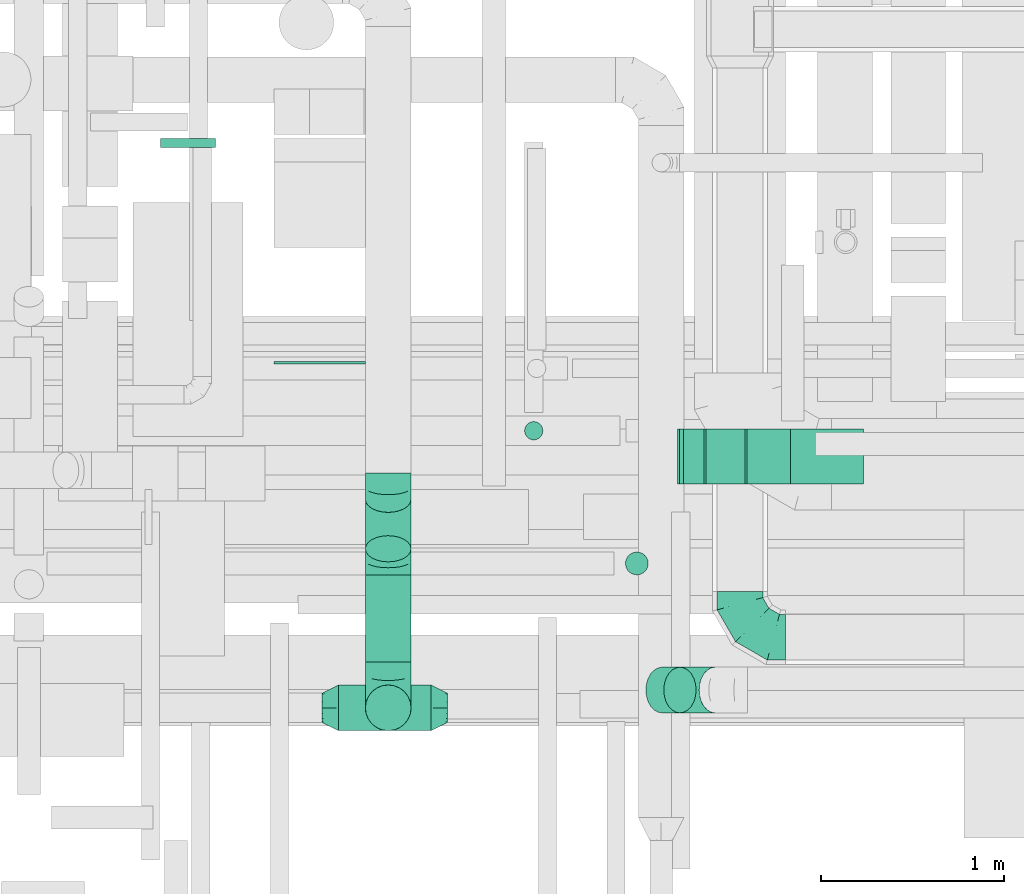
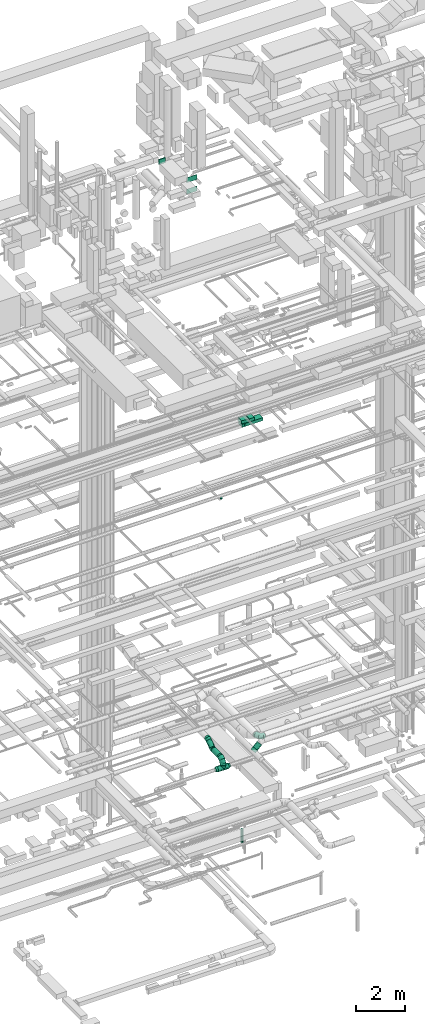
# One storey, part 142 of 337: 14 flow segments, 8 flow fittings.
"""IFC2X3 building model written with IfcOpenShell, lengths in millimetres."""

from ifc_helpers import new_model, entity, si_unit, converted_unit, derived_unit, direction, frame, frame_2d, origin, origin_2d_with_axis, place, context, subcontext, project, spatial, rectangle, circle, extrude, faceted_brep, source, transform, mapped, material, type_object, type_shapes, element, save


model = new_model("IFC2X3")

# Units and contexts
model_context = context("Model", 3, precision=0.01, world=origin(), true_north=direction((6.12303176911189e-17, 1.0)))
body_context = subcontext(model_context, "Body", "Model", "MODEL_VIEW")
ifc_project = project(units=[si_unit("LENGTHUNIT", "METRE", prefix="MILLI"), si_unit("AREAUNIT", "SQUARE_METRE"), si_unit("VOLUMEUNIT", "CUBIC_METRE"), converted_unit("PLANEANGLEUNIT", "DEGREE", entity("IfcRatioMeasure", 0.0174532925199433), si_unit("PLANEANGLEUNIT", "RADIAN"), dimensions=[0, 0, 0, 0, 0, 0, 0]), si_unit("MASSUNIT", "GRAM", prefix="KILO"), derived_unit("MASSDENSITYUNIT", [(si_unit("MASSUNIT", "GRAM", prefix="KILO"), 1), (si_unit("LENGTHUNIT", "METRE"), -3)]), derived_unit("MOMENTOFINERTIAUNIT", [(si_unit("LENGTHUNIT", "METRE"), 4)]), si_unit("TIMEUNIT", "SECOND"), si_unit("FREQUENCYUNIT", "HERTZ"), si_unit("THERMODYNAMICTEMPERATUREUNIT", "DEGREE_CELSIUS"), derived_unit("THERMALTRANSMITTANCEUNIT", [(si_unit("MASSUNIT", "GRAM", prefix="KILO"), 1), (si_unit("THERMODYNAMICTEMPERATUREUNIT", "KELVIN"), -1), (si_unit("TIMEUNIT", "SECOND"), -3)]), derived_unit("VOLUMETRICFLOWRATEUNIT", [(si_unit("LENGTHUNIT", "METRE"), 3), (si_unit("TIMEUNIT", "SECOND"), -1)]), derived_unit("MASSFLOWRATEUNIT", [(si_unit("MASSUNIT", "GRAM", prefix="KILO"), 1), (si_unit("TIMEUNIT", "SECOND"), -1)]), derived_unit("ROTATIONALFREQUENCYUNIT", [(si_unit("TIMEUNIT", "SECOND"), -1)]), si_unit("ELECTRICCURRENTUNIT", "AMPERE"), si_unit("ELECTRICVOLTAGEUNIT", "VOLT"), si_unit("POWERUNIT", "WATT"), si_unit("FORCEUNIT", "NEWTON", prefix="KILO"), si_unit("ILLUMINANCEUNIT", "LUX"), si_unit("LUMINOUSFLUXUNIT", "LUMEN"), si_unit("LUMINOUSINTENSITYUNIT", "CANDELA"), derived_unit("USERDEFINED", [(si_unit("MASSUNIT", "GRAM", prefix="KILO"), -1), (si_unit("LENGTHUNIT", "METRE"), -2), (si_unit("TIMEUNIT", "SECOND"), 3), (si_unit("LUMINOUSFLUXUNIT", "LUMEN"), 1)]), derived_unit("LINEARVELOCITYUNIT", [(si_unit("LENGTHUNIT", "METRE"), 1), (si_unit("TIMEUNIT", "SECOND"), -1)]), si_unit("PRESSUREUNIT", "PASCAL"), derived_unit("USERDEFINED", [(si_unit("LENGTHUNIT", "METRE"), -2), (si_unit("MASSUNIT", "GRAM", prefix="KILO"), 1), (si_unit("TIMEUNIT", "SECOND"), -2)]), derived_unit("LINEARFORCEUNIT", [(si_unit("MASSUNIT", "GRAM", prefix="KILO"), 1), (si_unit("LENGTHUNIT", "METRE"), 1), (si_unit("TIMEUNIT", "SECOND"), -2), (si_unit("LENGTHUNIT", "METRE"), -1)]), derived_unit("PLANARFORCEUNIT", [(si_unit("MASSUNIT", "GRAM", prefix="KILO"), 1), (si_unit("LENGTHUNIT", "METRE"), 1), (si_unit("TIMEUNIT", "SECOND"), -2), (si_unit("LENGTHUNIT", "METRE"), -2)])], contexts=[model_context])

# Site, building, storey
site_placement = place(None, origin())
site = spatial("IfcSite", under=ifc_project, at=site_placement, CompositionType="ELEMENT")
building_placement = place(site_placement, origin())
building = spatial("IfcBuilding", under=site, at=building_placement, CompositionType="ELEMENT")
storey_placement = place(building_placement, origin())
storey = spatial("IfcBuildingStorey", under=building, at=storey_placement, CompositionType="ELEMENT", Elevation=0.0)

# Flow segments
duct_segment_type_1 = type_object("IfcDuctSegmentType", PredefinedType="NOTDEFINED")
flow_segment_1_placement = place(storey_placement, frame((36571.74, 9425.61, 18590.0)))
element("IfcFlowSegment", 1, at=flow_segment_1_placement, inside=storey, type_object=duct_segment_type_1, context=body_context, shape_type="SweptSolid", body=[
    extrude(rectangle(XDim=848.292132121106, YDim=300.0, at=origin_2d_with_axis()), frame((424.15, 150.0, 0.0)), (0.0, 0.0, 1.0), 150.000000000001),
])
flow_segment_2_placement = place(storey_placement, frame((36784.11, 9425.09, 18750.0)))
element("IfcFlowSegment", 2, at=flow_segment_2_placement, inside=storey, type_object=duct_segment_type_1, context=body_context, shape_type="SweptSolid", body=[
    extrude(rectangle(XDim=235.998435102064, YDim=300.0, at=origin_2d_with_axis()), frame((118.0, 150.0, 0.0), z_axis=(0.0, 0.0, 1.0), x_axis=(-1.0, 0.0, 0.0)), (0.0, 0.0, 1.0), 150.000000000001),
])
flow_segment_3_placement = place(storey_placement, frame((36403.1, 9425.09, 18750.96)))
element("IfcFlowSegment", 3, at=flow_segment_3_placement, inside=storey, type_object=duct_segment_type_1, context=body_context, shape_type="SweptSolid", body=[
    extrude(rectangle(XDim=149.999999999999, YDim=299.999999999999, at=frame_2d((0.0, 0.0), x_axis=(0.0, 1.0))), frame((5.98, 150.0, 103.33), z_axis=(0.996815278738972, 0.0, -0.0797452197472972), x_axis=(0.0, 1.0, 0.0)), (0.0, 0.0, 1.0), 358.22680686157),
])
flow_segment_4_placement = place(storey_placement, frame((36436.92, 9425.61, 18580.9)))
element("IfcFlowSegment", 4, at=flow_segment_4_placement, inside=storey, type_object=duct_segment_type_1, context=body_context, shape_type="SweptSolid", body=[
    extrude(rectangle(XDim=150.000000000002, YDim=111.97128059236, at=frame_2d((0.0, 0.0), x_axis=(0.0, 1.0))), frame((61.61, 0.0, 79.1), z_axis=(0.0, 1.0, 0.0), x_axis=(-0.997008847092297, 0.0, -0.0772875075266911)), (0.0, 0.0, 1.0), 299.999999999999),
])
duct_segment_type_2 = type_object("IfcDuctSegmentType", PredefinedType="NOTDEFINED")
flow_segment_5_placement = place(storey_placement, frame((36116.53, 8925.87, -1728.0)))
element("IfcFlowSegment", 5, at=flow_segment_5_placement, inside=storey, type_object=duct_segment_type_2, context=body_context, shape_type="SweptSolid", body=[
    extrude(circle(Radius=62.5, at=origin_2d_with_axis()), frame((64.1, 64.1, 0.0), z_axis=(0.0, 0.0, 1.0), x_axis=(0.0, 1.0, 0.0)), (0.0, 0.0, 1.0), 653.000000000004),
])
flow_segment_6_placement = place(storey_placement, frame((34548.9, 8073.43, 2823.4)))
element("IfcFlowSegment", 6, at=flow_segment_6_placement, inside=storey, type_object=duct_segment_type_2, context=body_context, shape_type="SweptSolid", body=[
    extrude(circle(Radius=125.0, at=origin_2d_with_axis()), frame((0.0, 126.6, 126.6), z_axis=(1.0, 0.0, 0.0), x_axis=(0.0, -1.0, 0.0)), (0.0, 0.0, 1.0), 504.999999999993),
])
flow_segment_7_placement = place(storey_placement, frame((35564.72, 9664.09, 15150.0)))
element("IfcFlowSegment", 7, at=flow_segment_7_placement, inside=storey, type_object=duct_segment_type_2, context=body_context, shape_type="SweptSolid", body=[
    extrude(circle(Radius=50.0, at=origin_2d_with_axis()), frame((51.6, 51.6, 0.0)), (0.0, 0.0, 1.0), 49.9999996080384),
])
flow_segment_8_placement = place(storey_placement, frame((36326.28, 8170.92, 3192.71)))
element("IfcFlowSegment", 8, at=flow_segment_8_placement, inside=storey, type_object=duct_segment_type_2, context=body_context, shape_type="SweptSolid", body=[
    extrude(circle(Radius=125.0, at=origin_2d_with_axis()), frame((90.06, 126.6, 89.91), z_axis=(0.706492479137975, 0.0, 0.707720550020613), x_axis=(0.0, 1.0, 0.0)), (0.0, 0.0, 1.0), 274.124638638619),
])
flow_segment_9_placement = place(storey_placement, frame((34693.82, 8996.95, 3311.22)))
element("IfcFlowSegment", 9, at=flow_segment_9_placement, inside=storey, type_object=duct_segment_type_2, context=body_context, shape_type="SweptSolid", body=[
    extrude(circle(Radius=125.0, at=origin_2d_with_axis()), frame((126.6, 73.29, 103.99), z_axis=(0.0, 0.819152044288994, 0.573576436351043), x_axis=(1.0, 0.0, 0.0)), (0.0, 0.0, 1.0), 330.515708334412),
])
flow_segment_10_placement = place(storey_placement, frame((34693.82, 8450.02, 3243.4)))
element("IfcFlowSegment", 10, at=flow_segment_10_placement, inside=storey, type_object=duct_segment_type_2, context=body_context, shape_type="SweptSolid", body=[
    extrude(circle(Radius=125.0, at=origin_2d_with_axis()), frame((126.6, 0.0, 126.6), z_axis=(0.0, 1.0, 0.0), x_axis=(-1.0, 0.0, 0.0)), (0.0, 0.0, 1.0), 476.823539571613),
])
flow_segment_11_placement = place(storey_placement, frame((34693.82, 8073.43, 3095.0)))
element("IfcFlowSegment", 11, at=flow_segment_11_placement, inside=storey, type_object=duct_segment_type_2, context=body_context, shape_type="SweptSolid", body=[
    extrude(circle(Radius=125.0, at=origin_2d_with_axis()), frame((126.6, 126.6, 0.0), z_axis=(0.0, 0.0, 1.0), x_axis=(-1.0, 0.0, 0.0)), (0.0, 0.0, 1.0), 24.9999999998828),
])
duct_segment_type_3 = type_object("IfcDuctSegmentType", PredefinedType="NOTDEFINED")
flow_segment_12_placement = place(storey_placement, frame((33575.03, 11265.73, 31575.0)))
element("IfcFlowSegment", 12, at=flow_segment_12_placement, inside=storey, type_object=duct_segment_type_3, context=body_context, shape_type="SweptSolid", body=[
    extrude(rectangle(XDim=49.2338702333314, YDim=300.000000000001, at=origin_2d_with_axis()), frame((150.0, 24.62, 0.0), z_axis=(0.0, 0.0, 1.0), x_axis=(0.0, 1.0, 0.0)), (0.0, 0.0, 1.0), 250.000000000004),
])
flow_segment_13_placement = place(storey_placement, frame((34195.98, 10082.41, 30600.0)))
element("IfcFlowSegment", 13, at=flow_segment_13_placement, inside=storey, type_object=duct_segment_type_3, context=body_context, shape_type="SweptSolid", body=[
    extrude(rectangle(XDim=12.2733718566518, YDim=499.999999999999, at=origin_2d_with_axis()), frame((250.0, 6.14, 0.0), z_axis=(0.0, 0.0, 1.0), x_axis=(0.0, -1.0, 0.0)), (0.0, 0.0, 1.0), 250.000000000004),
])
flow_segment_14_placement = place(storey_placement, frame((34195.98, 10082.41, 31175.0)))
element("IfcFlowSegment", 14, at=flow_segment_14_placement, inside=storey, type_object=duct_segment_type_3, context=body_context, shape_type="SweptSolid", body=[
    extrude(rectangle(XDim=11.954017716561, YDim=499.999999999999, at=origin_2d_with_axis()), frame((250.0, 5.98, 0.0), z_axis=(0.0, 0.0, 1.0), x_axis=(0.0, -1.0, 0.0)), (0.0, 0.0, 1.0), 250.000000000004),
])

# Flow fittings
ifc_material = material()
duct_fitting_type_1 = type_object("IfcDuctFittingType", PredefinedType="NOTDEFINED", material=ifc_material)
shared_shape_1 = source(origin(), body_context, "Body", "Brep", [
    faceted_brep([(-250.0, 0.0, -125.0), (-250.0, -32.35, -120.74), (-250.0, -62.5, -108.25), (-250.0, -88.39, -88.39), (-250.0, -108.25, -62.5), (-250.0, -120.74, -32.35), (-250.0, -125.0, 0.0), (-250.0, -120.74, 32.35), (-250.0, -108.25, 62.5), (-250.0, -88.39, 88.39), (-250.0, -62.5, 108.25), (-250.0, -32.35, 120.74), (-250.0, 0.0, 125.0), (-250.0, 32.35, 120.74), (-250.0, 62.5, 108.25), (-250.0, 88.39, 88.39), (-250.0, 108.25, 62.5), (-250.0, 120.74, 32.35), (-250.0, 125.0, 0.0), (-250.0, 120.74, -32.35), (-250.0, 108.25, -62.5), (-250.0, 88.39, -88.39), (-250.0, 62.5, -108.25), (-250.0, 32.35, -120.74), (-191.68, 32.35, 120.74), (-199.76, 62.5, 108.25), (-183.01, 0.0, 125.0), (-206.7, 88.39, 88.39), (-215.37, 120.74, 32.35), (-216.51, 125.0, 0.0), (-212.02, 108.25, 62.5), (-212.02, 108.25, -62.5), (-206.7, 88.39, -88.39), (-215.37, 120.74, -32.35), (-191.68, 32.35, -120.74), (-183.01, 0.0, -125.0), (-199.76, 62.5, -108.25), (-174.34, -32.35, -120.74), (-166.27, -62.5, -108.25), (-159.33, -88.39, -88.39), (-154.01, -108.25, -62.5), (-150.66, -120.74, -32.35), (-149.52, -125.0, 0.0), (-150.66, -120.74, 32.35), (-154.01, -108.25, 62.5), (-159.33, -88.39, 88.39), (-166.27, -62.5, 108.25), (-174.34, -32.35, 120.74), (-90.67, 90.67, 120.74), (-112.74, 112.74, 108.25), (-66.99, 66.99, 125.0), (-131.69, 131.69, 88.39), (-146.23, 146.23, 62.5), (-155.38, 155.38, 32.35), (-158.49, 158.49, 0.0), (-155.38, 155.38, -32.35), (-146.23, 146.23, -62.5), (-131.69, 131.69, -88.39), (-90.67, 90.67, -120.74), (-66.99, 66.99, -125.0), (-112.74, 112.74, -108.25), (-43.3, 43.3, -120.74), (-21.23, 21.23, -108.25), (-2.28, 2.28, -88.39), (12.26, -12.26, -62.5), (21.4, -21.4, -32.35), (24.52, -24.52, 0.0), (21.4, -21.4, 32.35), (12.26, -12.26, 62.5), (-2.28, 2.28, 88.39), (-21.23, 21.23, 108.25), (-43.3, 43.3, 120.74), (-32.35, 191.68, 120.74), (-62.5, 199.76, 108.25), (0.0, 183.01, 125.0), (-88.39, 206.7, 88.39), (-108.25, 212.02, 62.5), (-120.74, 215.37, 32.35), (-125.0, 216.51, 0.0), (-120.74, 215.37, -32.35), (-108.25, 212.02, -62.5), (-88.39, 206.7, -88.39), (-32.35, 191.68, -120.74), (0.0, 183.01, -125.0), (-62.5, 199.76, -108.25), (32.35, 174.34, -120.74), (62.5, 166.27, -108.25), (88.39, 159.33, -88.39), (108.25, 154.01, -62.5), (120.74, 150.66, -32.35), (125.0, 149.52, 0.0), (120.74, 150.66, 32.35), (108.25, 154.01, 62.5), (88.39, 159.33, 88.39), (62.5, 166.27, 108.25), (32.35, 174.34, 120.74), (-32.35, 250.0, -120.74), (-62.5, 250.0, -108.25), (-88.39, 250.0, -88.39), (-108.25, 250.0, -62.5), (-120.74, 250.0, -32.35), (-125.0, 250.0, 0.0), (-120.74, 250.0, 32.35), (-108.25, 250.0, 62.5), (-88.39, 250.0, 88.39), (-62.5, 250.0, 108.25), (-32.35, 250.0, 120.74), (0.0, 250.0, 125.0), (32.35, 250.0, 120.74), (62.5, 250.0, 108.25), (88.39, 250.0, 88.39), (108.25, 250.0, 62.5), (120.74, 250.0, 32.35), (125.0, 250.0, 0.0), (120.74, 250.0, -32.35), (108.25, 250.0, -62.5), (88.39, 250.0, -88.39), (62.5, 250.0, -108.25), (32.35, 250.0, -120.74), (0.0, 250.0, -125.0)], [[[0, 1, 2, 3, 4, 5, 6, 7, 8, 9, 10, 11, 12, 13, 14, 15, 16, 17, 18, 19, 20, 21, 22, 23]], [[24, 25, 14, 13]], [[26, 24, 13, 12]], [[14, 25, 27, 15]], [[28, 29, 18, 17]], [[30, 28, 17, 16]], [[15, 27, 30, 16]], [[20, 31, 32, 21]], [[33, 31, 20, 19]], [[18, 29, 33, 19]], [[34, 35, 0, 23]], [[36, 34, 23, 22]], [[21, 32, 36, 22]], [[1, 0, 35, 37]], [[2, 1, 37, 38]], [[38, 39, 3, 2]], [[5, 4, 40, 41]], [[6, 5, 41, 42]], [[39, 40, 4, 3]], [[6, 42, 43, 7]], [[7, 43, 44, 8]], [[8, 44, 45, 9]], [[9, 45, 46, 10]], [[10, 46, 47, 11]], [[26, 12, 11, 47]], [[48, 49, 25, 24]], [[50, 48, 24, 26]], [[27, 25, 49, 51]], [[52, 53, 28, 30]], [[51, 52, 30, 27]], [[29, 28, 53, 54]], [[55, 56, 31, 33]], [[54, 55, 33, 29]], [[32, 31, 56, 57]], [[58, 59, 35, 34]], [[60, 58, 34, 36]], [[57, 60, 36, 32]], [[37, 35, 59, 61]], [[38, 37, 61, 62]], [[39, 38, 62, 63]], [[41, 40, 64, 65]], [[42, 41, 65, 66]], [[63, 64, 40, 39]], [[43, 42, 66, 67]], [[44, 43, 67, 68]], [[68, 69, 45, 44]], [[46, 45, 69, 70]], [[47, 46, 70, 71]], [[26, 47, 71, 50]], [[72, 73, 49, 48]], [[74, 72, 48, 50]], [[51, 49, 73, 75]], [[76, 77, 53, 52]], [[75, 76, 52, 51]], [[54, 53, 77, 78]], [[79, 80, 56, 55]], [[78, 79, 55, 54]], [[57, 56, 80, 81]], [[82, 83, 59, 58]], [[84, 82, 58, 60]], [[81, 84, 60, 57]], [[61, 59, 83, 85]], [[62, 61, 85, 86]], [[63, 62, 86, 87]], [[65, 64, 88, 89]], [[66, 65, 89, 90]], [[87, 88, 64, 63]], [[67, 66, 90, 91]], [[68, 67, 91, 92]], [[92, 93, 69, 68]], [[70, 69, 93, 94]], [[71, 70, 94, 95]], [[50, 71, 95, 74]], [[96, 97, 98, 99, 100, 101, 102, 103, 104, 105, 106, 107, 108, 109, 110, 111, 112, 113, 114, 115, 116, 117, 118, 119]], [[72, 74, 107, 106]], [[73, 72, 106, 105]], [[75, 73, 105, 104]], [[77, 76, 103, 102]], [[78, 77, 102, 101]], [[75, 104, 103, 76]], [[78, 101, 100, 79]], [[79, 100, 99, 80]], [[80, 99, 98, 81]], [[84, 97, 96, 82]], [[82, 96, 119, 83]], [[84, 81, 98, 97]], [[83, 119, 118, 85]], [[85, 118, 117, 86]], [[116, 87, 86, 117]], [[88, 115, 114, 89]], [[89, 114, 113, 90]], [[115, 88, 87, 116]], [[91, 90, 113, 112]], [[92, 91, 112, 111]], [[111, 110, 93, 92]], [[95, 94, 109, 108]], [[74, 95, 108, 107]], [[110, 109, 94, 93]]]),
])
type_shapes(duct_fitting_type_1, [shared_shape_1])
for number, where, z_axis, x_axis in (
    (15, (36744.56, 8586.67, 3550.0), (0.0, 0.0, 1.0), (0.0, -1.0, 0.0)),
    (16, (34820.41, 8200.02, 3370.0), (1.0, 0.0, 0.0), (0.0, -1.0, 0.0)),
):
    element("IfcFlowFitting", number, at=place(storey_placement, frame(where, z_axis=z_axis, x_axis=x_axis)), inside=storey, type_object=duct_fitting_type_1, material=ifc_material, context=body_context, shape_type="MappedRepresentation", body=[
        mapped(shared_shape_1, transform((0.0, 0.0, 0.0), scale=1.0)),
    ])
duct_fitting_type_2 = type_object("IfcDuctFittingType", PredefinedType="NOTDEFINED", material=ifc_material)
shared_shape_2 = source(origin(), body_context, "Body", "Brep", [
    faceted_brep([(90.0, -73.91, 30.61), (90.0, -76.96, 15.31), (90.0, -80.0, 0.0), (90.0, -76.96, -15.31), (90.0, -73.91, -30.61), (90.0, -65.24, -43.59), (90.0, -56.57, -56.57), (90.0, -43.59, -65.24), (90.0, -30.61, -73.91), (90.0, -15.31, -76.96), (90.0, 0.0, -80.0), (90.0, 15.31, -76.96), (90.0, 30.61, -73.91), (90.0, 43.59, -65.24), (90.0, 56.57, -56.57), (90.0, 65.24, -43.59), (90.0, 73.91, -30.61), (90.0, 76.96, -15.31), (90.0, 80.0, 0.0), (90.0, 76.96, 15.31), (90.0, 73.91, 30.61), (90.0, 65.24, 43.59), (90.0, 56.57, 56.57), (90.0, 43.59, 65.24), (90.0, 30.61, 73.91), (90.0, 15.31, 76.96), (90.0, 0.0, 80.0), (90.0, -15.31, 76.96), (90.0, -30.61, 73.91), (90.0, -43.59, 65.24), (90.0, -56.57, 56.57), (90.0, -65.24, 43.59), (0.0, -125.0, 0.0), (0.0, -118.88, 38.63), (0.0, -101.13, 73.47), (0.0, -73.47, 101.13), (0.0, -38.63, 118.88), (0.0, 0.0, 125.0), (0.0, 38.63, 118.88), (0.0, 73.47, 101.13), (0.0, 101.13, 73.47), (0.0, 118.88, 38.63), (0.0, 125.0, 0.0), (0.0, 118.88, -38.63), (0.0, 101.13, -73.47), (0.0, 73.47, -101.13), (0.0, 38.63, -118.88), (0.0, 0.0, -125.0), (0.0, -38.63, -118.88), (0.0, -73.47, -101.13), (0.0, -101.13, -73.47), (0.0, -118.88, -38.63)], [[[0, 1, 2, 3, 4, 5, 6, 7, 8, 9, 10, 11, 12, 13, 14, 15, 16, 17, 18, 19, 20, 21, 22, 23, 24, 25, 26, 27, 28, 29, 30, 31]], [[32, 33, 34, 35, 36, 37, 38, 39, 40, 41, 42, 43, 44, 45, 46, 47, 48, 49, 50, 51]], [[37, 25, 38]], [[24, 39, 38]], [[40, 22, 21, 20]], [[23, 22, 39, 24]], [[41, 20, 19]], [[18, 42, 19]], [[25, 24, 38]], [[40, 20, 41]], [[19, 42, 41]], [[25, 37, 26]], [[22, 40, 39]], [[32, 1, 33]], [[0, 34, 33]], [[35, 30, 29, 28]], [[31, 30, 34, 0]], [[36, 28, 27]], [[26, 37, 27]], [[1, 0, 33]], [[35, 28, 36]], [[27, 37, 36]], [[1, 32, 2]], [[30, 35, 34]], [[47, 9, 48]], [[8, 49, 48]], [[50, 6, 5, 4]], [[7, 6, 49, 8]], [[51, 4, 3]], [[2, 32, 3]], [[9, 8, 48]], [[50, 4, 51]], [[3, 32, 51]], [[9, 47, 10]], [[6, 50, 49]], [[42, 17, 43]], [[16, 44, 43]], [[45, 14, 13, 12]], [[15, 14, 44, 16]], [[46, 12, 11]], [[10, 47, 11]], [[17, 16, 43]], [[45, 12, 46]], [[11, 47, 46]], [[17, 42, 18]], [[14, 45, 44]]]),
])
type_shapes(duct_fitting_type_2, [shared_shape_2])
flow_fitting_1_placement = place(storey_placement, frame((34548.9, 8200.02, 2950.0), z_axis=(0.0, 0.0, 1.0), x_axis=(-1.0, 0.0, 0.0)))
element("IfcFlowFitting", 17, at=flow_fitting_1_placement, inside=storey, type_object=duct_fitting_type_2, material=ifc_material, context=body_context, shape_type="MappedRepresentation", body=[
    mapped(shared_shape_2, transform((0.0, 0.0, 0.0), scale=1.0)),
])
flow_fitting_2_placement = place(storey_placement, frame((35053.9, 8200.02, 2950.0)))
element("IfcFlowFitting", 18, at=flow_fitting_2_placement, inside=storey, type_object=duct_fitting_type_2, material=ifc_material, context=body_context, shape_type="MappedRepresentation", body=[
    mapped(shared_shape_2, transform((0.0, 0.0, 0.0), scale=1.0)),
])
duct_fitting_type_3 = type_object("IfcDuctFittingType", PredefinedType="NOTDEFINED", material=ifc_material)
shared_shape_3 = source(origin(), body_context, "Body", "Brep", [
    faceted_brep([(20.0, 0.0, -125.0), (20.0, 32.35, -120.74), (20.0, 62.5, -108.25), (20.0, 88.39, -88.39), (20.0, 108.25, -62.5), (20.0, 120.74, -32.35), (20.0, 125.0, 0.0), (20.0, 120.74, 32.35), (20.0, 108.25, 62.5), (20.0, 88.39, 88.39), (20.0, 62.5, 108.25), (20.0, 32.35, 120.74), (20.0, 0.0, 125.0), (20.0, -32.35, 120.74), (20.0, -62.5, 108.25), (20.0, -88.39, 88.39), (20.0, -108.25, 62.5), (20.0, -120.74, 32.35), (20.0, -125.0, 0.0), (20.0, -120.74, -32.35), (20.0, -108.25, -62.5), (20.0, -88.39, -88.39), (20.0, -62.5, -108.25), (20.0, -32.35, -120.74), (0.0, 0.0, 125.0), (-118.9, 0.0, 125.0), (-118.9, -32.35, 120.74), (0.0, -32.35, 120.74), (-118.9, -62.5, 108.25), (0.0, -62.5, 108.25), (0.0, -88.39, 88.39), (-118.9, -88.39, 88.39), (0.0, -108.25, 62.5), (-118.9, -108.25, 62.5), (-118.9, -120.74, 32.35), (0.0, -120.74, 32.35), (-118.9, -125.0, 0.0), (0.0, -125.0, 0.0), (-118.9, -120.74, -32.35), (0.0, -120.74, -32.35), (-118.9, -108.25, -62.5), (0.0, -108.25, -62.5), (0.0, -88.39, -88.39), (-118.9, -88.39, -88.39), (0.0, -62.5, -108.25), (-118.9, -62.5, -108.25), (-118.9, -32.35, -120.74), (0.0, -32.35, -120.74), (-118.9, 0.0, -125.0), (0.0, 0.0, -125.0), (-118.9, 32.35, -120.74), (0.0, 32.35, -120.74), (-118.9, 62.5, -108.25), (0.0, 62.5, -108.25), (0.0, 88.39, -88.39), (-118.9, 88.39, -88.39), (0.0, 108.25, -62.5), (-118.9, 108.25, -62.5), (-118.9, 120.74, -32.35), (0.0, 120.74, -32.35), (-118.9, 125.0, 0.0), (0.0, 125.0, 0.0), (-118.9, 120.74, 32.35), (0.0, 120.74, 32.35), (-118.9, 108.25, 62.5), (0.0, 108.25, 62.5), (0.0, 88.39, 88.39), (-118.9, 88.39, 88.39), (0.0, 62.5, 108.25), (-118.9, 62.5, 108.25), (-118.9, 32.35, 120.74), (0.0, 32.35, 120.74)], [[[0, 1, 2, 3, 4, 5, 6, 7, 8, 9, 10, 11, 12, 13, 14, 15, 16, 17, 18, 19, 20, 21, 22, 23]], [[13, 12, 24, 25, 26, 27]], [[14, 13, 27, 26, 28, 29]], [[30, 15, 14, 29, 28, 31]], [[17, 16, 32, 33, 34, 35]], [[18, 17, 35, 34, 36, 37]], [[32, 16, 15, 30, 31, 33]], [[19, 18, 37, 36, 38, 39]], [[20, 19, 39, 38, 40, 41]], [[42, 21, 20, 41, 40, 43]], [[23, 22, 44, 45, 46, 47]], [[0, 23, 47, 46, 48, 49]], [[44, 22, 21, 42, 43, 45]], [[1, 0, 49, 48, 50, 51]], [[2, 1, 51, 50, 52, 53]], [[54, 3, 2, 53, 52, 55]], [[5, 4, 56, 57, 58, 59]], [[6, 5, 59, 58, 60, 61]], [[56, 4, 3, 54, 55, 57]], [[7, 6, 61, 60, 62, 63]], [[8, 7, 63, 62, 64, 65]], [[66, 9, 8, 65, 64, 67]], [[11, 10, 68, 69, 70, 71]], [[12, 11, 71, 70, 25, 24]], [[68, 10, 9, 66, 67, 69]], [[46, 45, 43, 40, 38, 36, 34, 33, 31, 28, 26, 25, 70, 69, 67, 64, 62, 60, 58, 57, 55, 52, 50, 48]]]),
])
type_shapes(duct_fitting_type_3, [shared_shape_3])
flow_fitting_3_placement = place(storey_placement, frame((36402.21, 8297.51, 3268.47), z_axis=(0.707720550020635, 0.0, -0.706492479137952), x_axis=(0.706492479137954, 0.0, 0.707720550020634)))
element("IfcFlowFitting", 19, at=flow_fitting_3_placement, inside=storey, type_object=duct_fitting_type_3, material=ifc_material, context=body_context, shape_type="MappedRepresentation", body=[
    mapped(shared_shape_3, transform((0.0, 0.0, 0.0), scale=1.0)),
])
duct_fitting_type_4 = type_object("IfcDuctFittingType", PredefinedType="NOTDEFINED", material=ifc_material)
shared_shape_4 = source(origin(), body_context, "Body", "Brep", [
    faceted_brep([(20.0, 32.35, -120.74), (20.0, 62.5, -108.25), (20.0, 88.39, -88.39), (20.0, 108.25, -62.5), (20.0, 120.74, -32.35), (20.0, 125.0, 0.0), (20.0, 120.74, 32.35), (20.0, 108.25, 62.5), (20.0, 88.39, 88.39), (20.0, 62.5, 108.25), (20.0, 32.35, 120.74), (20.0, 0.0, 125.0), (20.0, -32.35, 120.74), (20.0, -62.5, 108.25), (20.0, -88.39, 88.39), (20.0, -108.25, 62.5), (20.0, -120.74, 32.35), (20.0, -125.0, 0.0), (20.0, -120.74, -32.35), (20.0, -108.25, -62.5), (20.0, -88.39, -88.39), (20.0, -62.5, -108.25), (20.0, -32.35, -120.74), (20.0, 0.0, -125.0), (0.0, 0.0, 125.0), (0.0, 32.35, 120.74), (-118.9, 32.35, 120.74), (-118.9, 0.0, 125.0), (0.0, 62.5, 108.25), (-118.9, 62.5, 108.25), (0.0, 88.39, 88.39), (-118.9, 88.39, 88.39), (0.0, 108.25, 62.5), (0.0, 120.74, 32.35), (-118.9, 120.74, 32.35), (-118.9, 108.25, 62.5), (0.0, 125.0, 0.0), (-118.9, 125.0, 0.0), (0.0, 120.74, -32.35), (-118.9, 120.74, -32.35), (0.0, 108.25, -62.5), (-118.9, 108.25, -62.5), (0.0, 88.39, -88.39), (-118.9, 88.39, -88.39), (0.0, 62.5, -108.25), (0.0, 32.35, -120.74), (-118.9, 32.35, -120.74), (-118.9, 62.5, -108.25), (0.0, 0.0, -125.0), (-118.9, 0.0, -125.0), (0.0, -32.35, -120.74), (-118.9, -32.35, -120.74), (0.0, -62.5, -108.25), (-118.9, -62.5, -108.25), (0.0, -88.39, -88.39), (-118.9, -88.39, -88.39), (0.0, -108.25, -62.5), (0.0, -120.74, -32.35), (-118.9, -120.74, -32.35), (-118.9, -108.25, -62.5), (0.0, -125.0, 0.0), (-118.9, -125.0, 0.0), (0.0, -120.74, 32.35), (-118.9, -120.74, 32.35), (0.0, -108.25, 62.5), (-118.9, -108.25, 62.5), (0.0, -88.39, 88.39), (-118.9, -88.39, 88.39), (0.0, -62.5, 108.25), (0.0, -32.35, 120.74), (-118.9, -32.35, 120.74), (-118.9, -62.5, 108.25)], [[[0, 1, 2, 3, 4, 5, 6, 7, 8, 9, 10, 11, 12, 13, 14, 15, 16, 17, 18, 19, 20, 21, 22, 23]], [[24, 11, 10, 25, 26, 27]], [[25, 10, 9, 28, 29, 26]], [[28, 9, 8, 30, 31, 29]], [[32, 7, 6, 33, 34, 35]], [[33, 6, 5, 36, 37, 34]], [[30, 8, 7, 32, 35, 31]], [[36, 5, 4, 38, 39, 37]], [[38, 4, 3, 40, 41, 39]], [[40, 3, 2, 42, 43, 41]], [[44, 1, 0, 45, 46, 47]], [[45, 0, 23, 48, 49, 46]], [[42, 2, 1, 44, 47, 43]], [[48, 23, 22, 50, 51, 49]], [[50, 22, 21, 52, 53, 51]], [[52, 21, 20, 54, 55, 53]], [[56, 19, 18, 57, 58, 59]], [[57, 18, 17, 60, 61, 58]], [[54, 20, 19, 56, 59, 55]], [[60, 17, 16, 62, 63, 61]], [[62, 16, 15, 64, 65, 63]], [[64, 15, 14, 66, 67, 65]], [[68, 13, 12, 69, 70, 71]], [[69, 12, 11, 24, 27, 70]], [[66, 14, 13, 68, 71, 67]], [[49, 51, 53, 55, 59, 58, 61, 63, 65, 67, 71, 70, 27, 26, 29, 31, 35, 34, 37, 39, 41, 43, 47, 46]]]),
])
type_shapes(duct_fitting_type_4, [shared_shape_4])
flow_fitting_4_placement = place(storey_placement, frame((34820.41, 8200.02, 3075.0), z_axis=(0.0, -1.0, 0.0), x_axis=(0.0, 0.0, 1.0)))
element("IfcFlowFitting", 20, at=flow_fitting_4_placement, inside=storey, type_object=duct_fitting_type_4, material=ifc_material, context=body_context, shape_type="MappedRepresentation", body=[
    mapped(shared_shape_4, transform((0.0, 0.0, 0.0), scale=1.0)),
])
duct_fitting_type_5 = type_object("IfcDuctFittingType", PredefinedType="NOTDEFINED", material=ifc_material)
shared_shape_5 = source(origin(), body_context, "Body", "Brep", [
    faceted_brep([(-78.82, 0.0, -125.0), (-78.82, -32.35, -120.74), (-78.82, -62.5, -108.25), (-78.82, -88.39, -88.39), (-78.82, -108.25, -62.5), (-78.82, -120.74, -32.35), (-78.82, -125.0, 0.0), (-78.82, -120.74, 32.35), (-78.82, -108.25, 62.5), (-78.82, -88.39, 88.39), (-78.82, -62.5, 108.25), (-78.82, -32.35, 120.74), (-78.82, 0.0, 125.0), (-78.82, 32.35, 120.74), (-78.82, 62.5, 108.25), (-78.82, 88.39, 88.39), (-78.82, 108.25, 62.5), (-78.82, 120.74, 32.35), (-78.82, 125.0, 0.0), (-78.82, 120.74, -32.35), (-78.82, 108.25, -62.5), (-78.82, 88.39, -88.39), (-78.82, 62.5, -108.25), (-78.82, 32.35, -120.74), (-10.2, 32.35, 120.74), (-19.71, 62.5, 108.25), (0.0, 0.0, 125.0), (-27.87, 88.39, 88.39), (-34.13, 108.25, 62.5), (-38.07, 120.74, 32.35), (-39.41, 125.0, 0.0), (-38.07, 120.74, -32.35), (-34.13, 108.25, -62.5), (-27.87, 88.39, -88.39), (-10.2, 32.35, -120.74), (0.0, 0.0, -125.0), (-19.71, 62.5, -108.25), (10.2, -32.35, -120.74), (19.71, -62.5, -108.25), (27.87, -88.39, -88.39), (34.13, -108.25, -62.5), (38.07, -120.74, -32.35), (39.41, -125.0, 0.0), (38.07, -120.74, 32.35), (34.13, -108.25, 62.5), (27.87, -88.39, 88.39), (19.71, -62.5, 108.25), (10.2, -32.35, 120.74), (46.01, 71.71, 120.74), (28.72, 96.41, 108.25), (64.57, 45.21, 125.0), (13.87, 117.62, 88.39), (2.48, 133.89, 62.5), (-4.68, 144.12, 32.35), (-7.13, 147.61, 0.0), (-4.68, 144.12, -32.35), (2.48, 133.89, -62.5), (13.87, 117.62, -88.39), (28.72, 96.41, -108.25), (46.01, 71.71, -120.74), (64.57, 45.21, -125.0), (83.13, 18.71, -120.74), (100.42, -5.99, -108.25), (115.27, -27.19, -88.39), (126.66, -43.46, -62.5), (133.82, -53.69, -32.35), (136.27, -57.18, 0.0), (133.82, -53.69, 32.35), (126.66, -43.46, 62.5), (115.27, -27.19, 88.39), (100.42, -5.99, 108.25), (83.13, 18.71, 120.74)], [[[0, 1, 2, 3, 4, 5, 6, 7, 8, 9, 10, 11, 12, 13, 14, 15, 16, 17, 18, 19, 20, 21, 22, 23]], [[24, 25, 14, 13]], [[26, 24, 13, 12]], [[14, 25, 27, 15]], [[28, 29, 17, 16]], [[28, 16, 15, 27]], [[30, 18, 17, 29]], [[31, 32, 20, 19]], [[30, 31, 19, 18]], [[32, 33, 21, 20]], [[34, 35, 0, 23]], [[36, 34, 23, 22]], [[33, 36, 22, 21]], [[1, 0, 35, 37]], [[2, 1, 37, 38]], [[38, 39, 3, 2]], [[5, 4, 40, 41]], [[6, 5, 41, 42]], [[39, 40, 4, 3]], [[6, 42, 43, 7]], [[7, 43, 44, 8]], [[8, 44, 45, 9]], [[9, 45, 46, 10]], [[10, 46, 47, 11]], [[26, 12, 11, 47]], [[48, 49, 25, 24]], [[50, 48, 24, 26]], [[27, 25, 49, 51]], [[29, 28, 52, 53]], [[30, 29, 53, 54]], [[51, 52, 28, 27]], [[30, 54, 55, 31]], [[31, 55, 56, 32]], [[57, 33, 32, 56]], [[36, 58, 59, 34]], [[34, 59, 60, 35]], [[58, 36, 33, 57]], [[35, 60, 61, 37]], [[37, 61, 62, 38]], [[63, 39, 38, 62]], [[40, 64, 65, 41]], [[41, 65, 66, 42]], [[64, 40, 39, 63]], [[43, 42, 66, 67]], [[44, 43, 67, 68]], [[68, 69, 45, 44]], [[47, 46, 70, 71]], [[26, 47, 71, 50]], [[69, 70, 46, 45]], [[59, 58, 57, 56, 55, 54, 53, 52, 51, 49, 48, 50, 71, 70, 69, 68, 67, 66, 65, 64, 63, 62, 61, 60]]]),
])
type_shapes(duct_fitting_type_5, [shared_shape_5])
for number, where, z_axis, x_axis in (
    (21, (34820.41, 9005.67, 3370.0), (1.0, 0.0, 0.0), (0.0, 1.0, 0.0)),
    (22, (34820.41, 9405.55, 3650.0), (1.0, 0.0, 0.0), (0.0, -1.0, 0.0)),
):
    element("IfcFlowFitting", number, at=place(storey_placement, frame(where, z_axis=z_axis, x_axis=x_axis)), inside=storey, type_object=duct_fitting_type_5, material=ifc_material, context=body_context, shape_type="MappedRepresentation", body=[
        mapped(shared_shape_5, transform((0.0, 0.0, 0.0), scale=1.0)),
    ])

save(model, "model.ifc")
